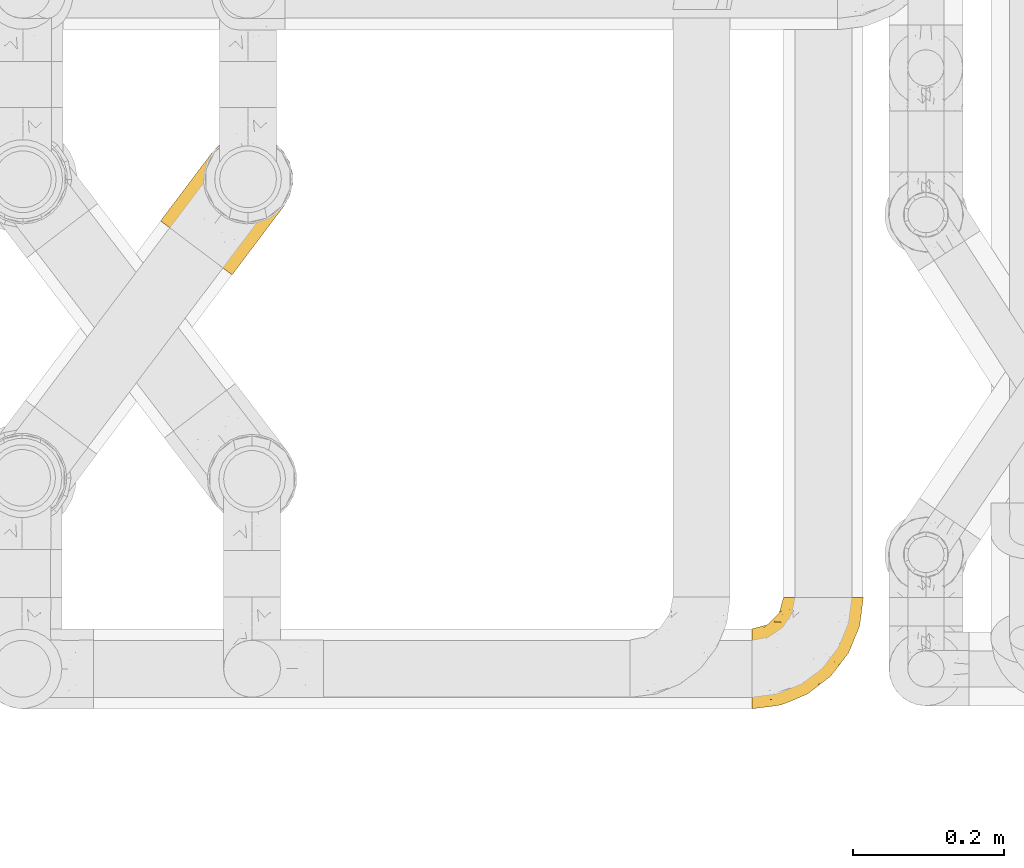
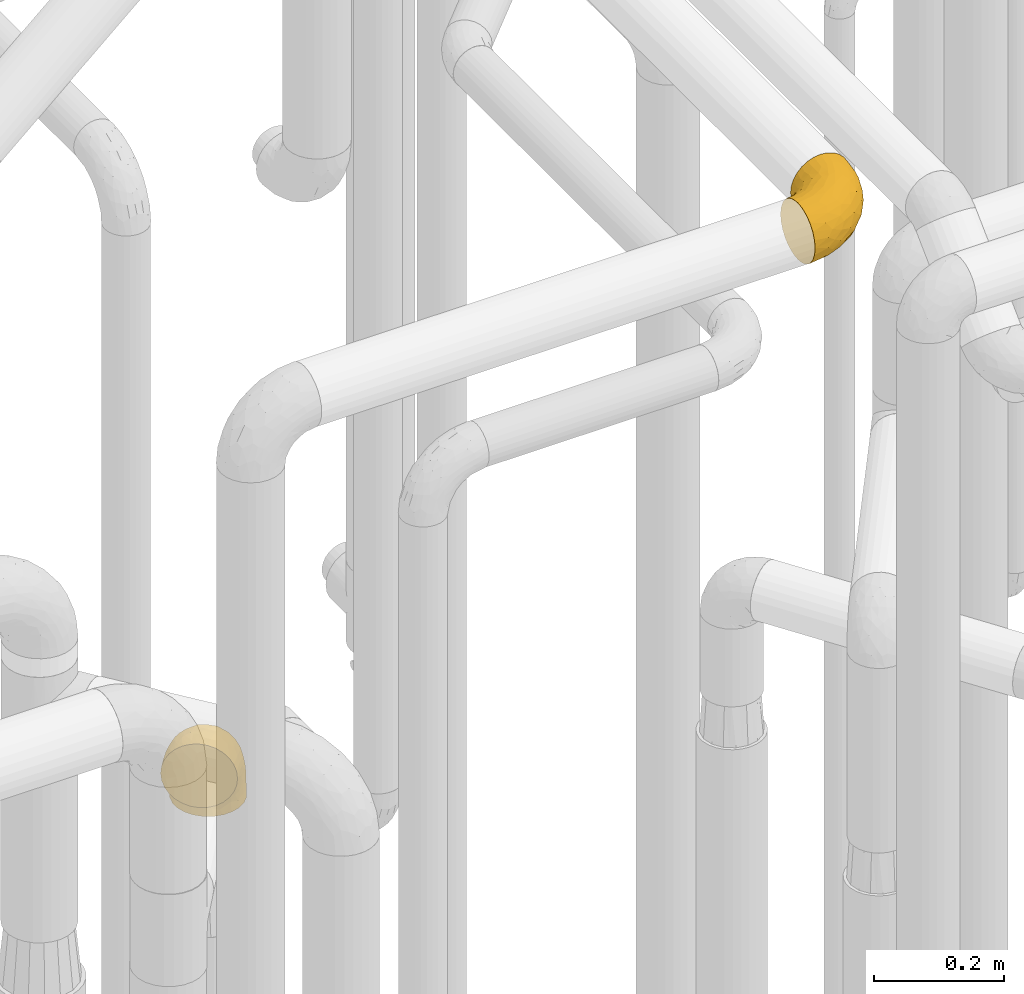
# One storey, part 383 of 827: 2 coverings.
"""IFC2X3 building model written with IfcOpenShell, lengths in millimetres."""

import ifcopenshell
import ifcopenshell.guid

model = None  # the IFC model being written
_history = None  # IfcOwnerHistory: only IFC2X3 demands one
_inside = {}  # id of a spatial element -> (the spatial element, [elements in it])
_under = {}  # id of a project, library or spatial element -> (it, [spatial elements below it])
_declared = {}  # id of a project -> (the project, [libraries it declares])
_typed = {}  # id of a type object -> (the type object, [elements of that type])
_made_of = {}  # id of a material, layer set ... -> (it, [elements and type objects made of it])


def new_model(schema):
    """Start an empty IFC model of exactly this schema.

    Asked for "IFC4X3", IfcOpenShell would pick the latest addendum, in which some entities
    have other attributes; the version numbers below select the first issue.
    IFC2X3 requires an IfcOwnerHistory on every rooted entity: one is made here for all.
    """
    global model, _history
    if schema == "IFC4X3":
        model = ifcopenshell.file(schema_version=(4, 3, 0, 0))
    else:
        model = ifcopenshell.file(schema=schema)
    _inside.clear()
    _under.clear()
    _declared.clear()
    _typed.clear()
    _made_of.clear()
    _history = None
    if model.schema == "IFC2X3":
        org = make("IfcOrganization", Name="unknown")
        user = make(
            "IfcPersonAndOrganization",
            ThePerson=make("IfcPerson", FamilyName="unknown"),
            TheOrganization=org,
        )
        app = make(
            "IfcApplication",
            ApplicationDeveloper=org,
            Version="unknown",
            ApplicationFullName="unknown",
            ApplicationIdentifier="unknown",
        )
        _history = make(
            "IfcOwnerHistory",
            OwningUser=user,
            OwningApplication=app,
            ChangeAction="ADDED",
            CreationDate=0,
        )
    return model


def make(cls, **values):
    """One entity of the class cls with the attributes given. An attribute that is None is left unset."""
    return model.create_entity(
        cls, **{name: value for name, value in values.items() if value is not None}
    )


def entity(cls, *values):
    """Any entity or typed value of the class cls, its attributes in the order of the schema. None: left unset."""
    e = model.create_entity(cls)
    for i, value in enumerate(values):
        if value is not None:
            e[i] = value
    return e


def rooted(cls, **values):
    """An entity with a GlobalId (a new one), such as an element, a storey or a relation."""
    return make(cls, GlobalId=ifcopenshell.guid.new(), OwnerHistory=_history, **values)


def si_unit(unit_type, name, prefix=None):
    """IfcSIUnit, for example si_unit("LENGTHUNIT", "METRE", prefix="MILLI")."""
    return make("IfcSIUnit", UnitType=unit_type, Prefix=prefix, Name=name)


def converted_unit(unit_type, name, factor, base, dimensions=None, offset=None):
    """IfcConversionBasedUnit, such as the inch: factor (a typed value) times the base unit."""
    return make(
        "IfcConversionBasedUnit"
        if offset is None
        else "IfcConversionBasedUnitWithOffset",
        ConversionOffset=offset,
        Dimensions=None
        if dimensions is None
        else entity("IfcDimensionalExponents", *dimensions),
        UnitType=unit_type,
        Name=name,
        ConversionFactor=make(
            "IfcMeasureWithUnit", ValueComponent=factor, UnitComponent=base
        ),
    )


def derived_unit(unit_type, elements):
    """IfcDerivedUnit: a product of units, each with its exponent."""
    return make(
        "IfcDerivedUnit",
        Elements=[
            make("IfcDerivedUnitElement", Unit=unit, Exponent=power)
            for unit, power in elements
        ],
        UnitType=unit_type,
    )


def assignment(units):
    """IfcUnitAssignment: the units of a project."""
    return None if units is None else make("IfcUnitAssignment", Units=units)


def point(xyz):
    """IfcCartesianPoint."""
    return None if xyz is None else make("IfcCartesianPoint", Coordinates=xyz)


def direction(xyz):
    """IfcDirection."""
    return None if xyz is None else make("IfcDirection", DirectionRatios=xyz)


def frame(location, z_axis=None, x_axis=None):
    """IfcAxis2Placement3D, a coordinate frame: its origin and axes. An axis left out is left unset."""
    return make(
        "IfcAxis2Placement3D",
        Location=point(location),
        Axis=direction(z_axis),
        RefDirection=direction(x_axis),
    )


def origin():
    """The frame at (0, 0, 0) with its axes left unset."""
    return frame((0.0, 0.0, 0.0))


def place(relative_to, where):
    """IfcLocalPlacement: puts the frame where relative to a parent placement (None: the world)."""
    return make(
        "IfcLocalPlacement", PlacementRelTo=relative_to, RelativePlacement=where
    )


def context(
    kind, dimensions, precision=None, world=None, true_north=None, identifier=None
):
    """IfcGeometricRepresentationContext, for example the 3D "Model" context."""
    return make(
        "IfcGeometricRepresentationContext",
        ContextIdentifier=identifier,
        ContextType=kind,
        CoordinateSpaceDimension=dimensions,
        Precision=precision,
        WorldCoordinateSystem=world,
        TrueNorth=true_north,
    )


def subcontext(parent, identifier, kind, view, scale=None):
    """IfcGeometricRepresentationSubContext, for example "Body" below "Model"."""
    return make(
        "IfcGeometricRepresentationSubContext",
        ContextIdentifier=identifier,
        ContextType=kind,
        ParentContext=parent,
        TargetScale=scale,
        TargetView=view,
    )


def project(units=None, contexts=None):
    """IfcProject with its units and contexts."""
    return rooted(
        "IfcProject",
        Name="project",
        RepresentationContexts=contexts,
        UnitsInContext=assignment(units),
    )


def spatial(cls, under=None, at=None, **own):
    """A site, building, storey or space (cls), placed at a placement, below another one or the project."""
    s = rooted(cls, ObjectPlacement=at, **own)
    if under is not None:
        _under.setdefault(under.id(), (under, []))[1].append(s)
    return s


def faces_of(points, faces, orient=None, outer=None):
    """IfcFace entities. A face is a list of loops; a loop is a list of indices into points, from 0.

    orient and outer hold one flag for each loop. By default every Orientation is true, the
    first loop of a face is its IfcFaceOuterBound and the others are IfcFaceBound.
    """
    made = []
    for i, loops in enumerate(faces):
        bounds = []
        for j, loop in enumerate(loops):
            is_outer = j == 0 if outer is None else outer[i][j]
            bounds.append(
                make(
                    "IfcFaceOuterBound" if is_outer else "IfcFaceBound",
                    Bound=make("IfcPolyLoop", Polygon=[points[k] for k in loop]),
                    Orientation=True if orient is None else orient[i][j],
                )
            )
        made.append(make("IfcFace", Bounds=bounds))
    return made


def faceted_brep(points, faces, orient=None, outer=None, voids=None):
    """IfcFacetedBrep: a solid bounded by flat faces; with voids (closed shells), ...WithVoids."""
    shared = [point(p) for p in points]
    hull = make("IfcClosedShell", CfsFaces=faces_of(shared, faces, orient, outer))
    if voids is None:
        return make("IfcFacetedBrep", Outer=hull)
    return make(
        "IfcFacetedBrepWithVoids",
        Outer=hull,
        Voids=[
            make(cls, CfsFaces=faces_of(shared, fs, o, b)) for cls, fs, o, b in voids
        ],
    )


def shape(context_of_items, identifier, shape_type, items):
    """IfcShapeRepresentation: the items that make up one representation, for example the "Body"."""
    return make(
        "IfcShapeRepresentation",
        ContextOfItems=context_of_items,
        RepresentationIdentifier=identifier,
        RepresentationType=shape_type,
        Items=items,
    )


def made_of(thing, what):
    """Note that an element or type object is made of a material, layer set ...; save() writes the relation."""
    if what is not None:
        _made_of.setdefault(what.id(), (what, []))[1].append(thing)
    return thing


def element(
    cls,
    number,
    at=None,
    inside=None,
    cuts=None,
    type_object=None,
    material=None,
    context=None,
    identifier="Body",
    shape_type=None,
    held_by="IfcProductDefinitionShape",
    body=None,
    shapes=None,
    **own,
):
    """One element of the class cls, such as IfcWall. Its Tag is "e" and its number.

    at: its placement. inside: the storey or other place that contains it. cuts: it is an
    opening in that element (IfcRelVoidsElement). A single representation is given by context,
    identifier, shape_type and body (its items); several are given by shapes. held_by: the class
    of the entity that holds the representations. save() writes the other relations.
    """
    e = rooted(cls, Tag="e%d" % number, ObjectPlacement=at, **own)
    if body is not None:
        shapes = [shape(context, identifier, shape_type, body)]
    if shapes is not None:
        e.Representation = make(held_by, Representations=shapes)
    if inside is not None:
        _inside.setdefault(inside.id(), (inside, []))[1].append(e)
    if cuts is not None:
        rooted(
            "IfcRelVoidsElement", RelatingBuildingElement=cuts, RelatedOpeningElement=e
        )
    if type_object is not None:
        _typed.setdefault(type_object.id(), (type_object, []))[1].append(e)
    return made_of(e, material)


def aggregate(whole, parts):
    """IfcRelAggregates: a whole, such as a stair, and the parts it consists of."""
    return rooted("IfcRelAggregates", RelatingObject=whole, RelatedObjects=parts)


def save(model, path):
    """Write the relations noted so far, then the file.

    IfcRelAggregates (storeys below a building ...), IfcRelContainedInSpatialStructure (elements
    in a storey), IfcRelDefinesByType, IfcRelAssociatesMaterial and IfcRelDeclares: one each for
    every whole, place, type object, material and project.
    """
    for whole, parts in _under.values():
        aggregate(whole, parts)
    for where, things in _inside.values():
        rooted(
            "IfcRelContainedInSpatialStructure",
            RelatedElements=things,
            RelatingStructure=where,
        )
    for kind, things in _typed.values():
        rooted("IfcRelDefinesByType", RelatedObjects=things, RelatingType=kind)
    for what, things in _made_of.values():
        rooted("IfcRelAssociatesMaterial", RelatedObjects=things, RelatingMaterial=what)
    for by, libraries in _declared.values():
        rooted("IfcRelDeclares", RelatingContext=by, RelatedDefinitions=libraries)
    model.write(path)


model = new_model("IFC2X3")

# Units and contexts
model_context = context("Model", 3, precision=0.01, world=origin(), true_north=direction((6.12303176911189e-17, 1.0)))
body_context = subcontext(model_context, "Body", "Model", "MODEL_VIEW")
ifc_project = project(units=[si_unit("LENGTHUNIT", "METRE", prefix="MILLI"), si_unit("AREAUNIT", "SQUARE_METRE"), si_unit("VOLUMEUNIT", "CUBIC_METRE"), converted_unit("PLANEANGLEUNIT", "DEGREE", entity("IfcRatioMeasure", 0.0174532925199433), si_unit("PLANEANGLEUNIT", "RADIAN"), dimensions=[0, 0, 0, 0, 0, 0, 0]), si_unit("MASSUNIT", "GRAM", prefix="KILO"), derived_unit("MASSDENSITYUNIT", [(si_unit("MASSUNIT", "GRAM", prefix="KILO"), 1), (si_unit("LENGTHUNIT", "METRE"), -3)]), derived_unit("MOMENTOFINERTIAUNIT", [(si_unit("LENGTHUNIT", "METRE"), 4)]), si_unit("TIMEUNIT", "SECOND"), si_unit("FREQUENCYUNIT", "HERTZ"), si_unit("THERMODYNAMICTEMPERATUREUNIT", "DEGREE_CELSIUS"), derived_unit("THERMALTRANSMITTANCEUNIT", [(si_unit("MASSUNIT", "GRAM", prefix="KILO"), 1), (si_unit("THERMODYNAMICTEMPERATUREUNIT", "KELVIN"), -1), (si_unit("TIMEUNIT", "SECOND"), -3)]), derived_unit("VOLUMETRICFLOWRATEUNIT", [(si_unit("LENGTHUNIT", "METRE"), 3), (si_unit("TIMEUNIT", "SECOND"), -1)]), derived_unit("MASSFLOWRATEUNIT", [(si_unit("MASSUNIT", "GRAM", prefix="KILO"), 1), (si_unit("TIMEUNIT", "SECOND"), -1)]), derived_unit("ROTATIONALFREQUENCYUNIT", [(si_unit("TIMEUNIT", "SECOND"), -1)]), si_unit("ELECTRICCURRENTUNIT", "AMPERE"), si_unit("ELECTRICVOLTAGEUNIT", "VOLT"), si_unit("POWERUNIT", "WATT"), si_unit("FORCEUNIT", "NEWTON", prefix="KILO"), si_unit("ILLUMINANCEUNIT", "LUX"), si_unit("LUMINOUSFLUXUNIT", "LUMEN"), si_unit("LUMINOUSINTENSITYUNIT", "CANDELA"), derived_unit("USERDEFINED", [(si_unit("MASSUNIT", "GRAM", prefix="KILO"), -1), (si_unit("LENGTHUNIT", "METRE"), -2), (si_unit("TIMEUNIT", "SECOND"), 3), (si_unit("LUMINOUSFLUXUNIT", "LUMEN"), 1)]), derived_unit("LINEARVELOCITYUNIT", [(si_unit("LENGTHUNIT", "METRE"), 1), (si_unit("TIMEUNIT", "SECOND"), -1)]), si_unit("PRESSUREUNIT", "PASCAL"), derived_unit("USERDEFINED", [(si_unit("LENGTHUNIT", "METRE"), -2), (si_unit("MASSUNIT", "GRAM", prefix="KILO"), 1), (si_unit("TIMEUNIT", "SECOND"), -2)]), derived_unit("LINEARFORCEUNIT", [(si_unit("MASSUNIT", "GRAM", prefix="KILO"), 1), (si_unit("LENGTHUNIT", "METRE"), 1), (si_unit("TIMEUNIT", "SECOND"), -2), (si_unit("LENGTHUNIT", "METRE"), -1)]), derived_unit("PLANARFORCEUNIT", [(si_unit("MASSUNIT", "GRAM", prefix="KILO"), 1), (si_unit("LENGTHUNIT", "METRE"), 1), (si_unit("TIMEUNIT", "SECOND"), -2), (si_unit("LENGTHUNIT", "METRE"), -2)])], contexts=[model_context])

# Site, building, storey
site_placement = place(None, origin())
site = spatial("IfcSite", under=ifc_project, at=site_placement, CompositionType="ELEMENT")
building_placement = place(site_placement, origin())
building = spatial("IfcBuilding", under=site, at=building_placement, CompositionType="ELEMENT")
storey_placement = place(building_placement, frame((0.0, 0.0, 28200.0)))
storey = spatial("IfcBuildingStorey", under=building, at=storey_placement, Name="08", CompositionType="ELEMENT", Elevation=28200.0)

# Coverings
covering_1_placement = place(storey_placement, frame((46460.18, 13582.19, 3145.4)))
element("IfcCovering", 1, at=covering_1_placement, inside=storey, Name=":ADSK_", ObjectType=":ADSK_", PredefinedType="INSULATION", context=body_context, shape_type="Brep", body=[
    faceted_brep([(148.32, 149.65, 66.44), (149.65, 149.65, 54.65), (148.31, 149.65, 42.84), (144.39, 149.65, 31.62), (138.06, 149.65, 21.56), (129.66, 149.65, 13.16), (119.6, 149.65, 6.84), (108.39, 149.65, 2.92), (96.6, 149.65, 1.6), (84.79, 149.65, 2.93), (73.57, 149.65, 6.85), (63.51, 149.65, 13.18), (55.11, 149.65, 21.58), (48.79, 149.65, 31.64), (44.87, 149.65, 42.85), (43.55, 149.65, 54.65), (44.88, 149.65, 66.46), (48.8, 149.65, 77.67), (55.13, 149.65, 87.73), (63.53, 149.65, 96.13), (73.59, 149.65, 102.45), (84.8, 149.65, 106.37), (96.6, 149.65, 107.7), (108.41, 149.65, 106.36), (119.62, 149.65, 102.44), (129.68, 149.65, 96.11), (138.08, 149.65, 87.71), (144.4, 149.65, 77.65), (1.6, 105.89, 40.91), (1.6, 100.59, 28.12), (1.6, 92.16, 17.13), (1.6, 81.17, 8.7), (1.6, 68.38, 3.4), (1.6, 54.65, 1.6), (1.6, 40.91, 3.4), (1.6, 28.12, 8.7), (1.6, 17.13, 17.13), (1.6, 8.7, 28.12), (1.6, 3.4, 40.91), (1.6, 1.6, 54.65), (1.6, 3.4, 68.38), (1.6, 8.7, 81.17), (1.6, 17.13, 92.16), (1.6, 28.12, 100.59), (1.6, 40.91, 105.89), (1.6, 54.65, 107.7), (1.6, 68.38, 105.89), (1.6, 81.17, 100.59), (1.6, 92.16, 92.16), (1.6, 100.59, 81.17), (1.6, 105.89, 68.38), (1.6, 107.7, 54.65), (27.97, 14.05, 85.53), (37.09, 9.45, 73.42), (58.27, 22.36, 83.77), (27.13, 4.7, 64.22), (39.91, 6.64, 54.65), (109.11, 81.47, 96.72), (94.41, 56.83, 93.36), (110.94, 64.02, 84.47), (89.69, 34.04, 71.37), (75.62, 21.43, 54.65), (106.28, 44.96, 54.65), (60.12, 49.8, 103.47), (41.41, 35.43, 100.91), (63.22, 42.1, 99.1), (32.05, 43.59, 105.43), (52.13, 57.88, 106.79), (123.27, 91.8, 89.81), (129.32, 88.01, 79.59), (138.3, 115.65, 81.29), (62.95, 18.94, 74.01), (55.89, 12.83, 64.14), (37.4, 24.96, 94.75), (144.6, 111.33, 54.65), (142.66, 113.8, 70.74), (117.85, 60.89, 68.3), (134.01, 86.24, 66.05), (89.25, 65.84, 100.73), (103.34, 124.58, 106.78), (113.52, 121.36, 103.6), (57.43, 72.79, 107.7), (44.19, 66.04, 107.7), (30.95, 59.29, 107.7), (77.98, 73.26, 106.07), (132.66, 121.69, 90.59), (121.52, 109.82, 97.43), (86.93, 40.11, 84.51), (68.4, 36.57, 93.3), (78.45, 93.81, 107.7), (67.94, 83.3, 107.7), (94.53, 136.6, 107.7), (91.95, 120.29, 107.7), (93.36, 99.11, 106.79), (85.2, 107.05, 107.7), (101.45, 91.12, 103.47), (129.81, 75.62, 54.65), (16.27, 56.97, 107.7), (42.46, 126.65, 76.99), (40.4, 116.55, 84.28), (49.71, 120.09, 91.11), (39.4, 76.06, 106.26), (31.26, 83.69, 102.6), (27.7, 71.88, 106.08), (16.7, 66.92, 106.56), (70.67, 110.43, 105.36), (81.69, 121.31, 106.74), (16.68, 81.0, 101.59), (22.57, 113.32, 54.65), (14.26, 111.09, 54.65), (17.68, 109.14, 67.71), (19.58, 95.86, 91.36), (33.49, 99.07, 94.33), (33.01, 106.92, 87.1), (40.69, 131.39, 65.84), (40.15, 136.98, 54.65), (37.93, 128.67, 54.65), (31.04, 117.07, 68.92), (45.29, 96.39, 100.82), (23.55, 106.61, 79.83), (11.36, 103.72, 77.13), (59.1, 92.14, 105.9), (57.42, 107.13, 101.53), (68.96, 98.03, 106.72), (20.38, 88.38, 97.75), (72.46, 130.66, 103.08), (83.66, 135.45, 106.39), (60.66, 123.57, 98.1), (61.01, 137.75, 95.02), (51.85, 133.2, 86.9), (46.07, 138.8, 74.42), (30.25, 120.99, 54.65), (46.65, 84.53, 105.28), (43.0, 108.72, 92.87), (19.58, 95.86, 17.93), (72.44, 130.67, 6.22), (17.67, 109.13, 41.58), (78.45, 93.81, 1.6), (68.97, 98.02, 2.57), (70.65, 110.43, 3.94), (40.69, 131.4, 43.46), (42.45, 126.66, 32.32), (31.04, 117.08, 40.38), (42.99, 108.74, 16.44), (45.18, 96.31, 8.47), (33.46, 99.11, 15.01), (60.64, 123.58, 11.21), (57.37, 107.12, 7.78), (57.43, 72.79, 1.6), (44.19, 66.04, 1.6), (39.35, 76.07, 3.04), (16.27, 56.97, 1.6), (16.7, 66.92, 2.73), (91.95, 120.29, 1.6), (85.2, 107.05, 1.6), (81.68, 121.26, 2.55), (46.68, 84.46, 3.98), (31.26, 83.69, 6.69), (16.68, 81.0, 7.7), (27.7, 71.88, 3.21), (60.99, 137.76, 14.28), (51.84, 133.21, 22.42), (40.41, 116.58, 25.02), (49.72, 120.1, 18.18), (46.06, 138.81, 34.89), (94.53, 136.6, 1.6), (11.35, 103.72, 32.17), (33.02, 106.96, 22.23), (83.65, 135.44, 2.91), (20.38, 88.38, 11.54), (67.94, 83.3, 1.6), (23.53, 106.6, 29.46), (59.12, 92.12, 3.38), (30.95, 59.29, 1.6), (58.27, 22.36, 25.52), (27.97, 14.05, 23.76), (37.4, 24.96, 14.54), (41.41, 35.43, 8.38), (27.21, 4.71, 45.07), (37.09, 9.45, 35.87), (53.2, 11.79, 45.14), (52.13, 57.88, 2.5), (103.34, 124.57, 2.51), (113.5, 121.37, 5.68), (101.45, 91.12, 5.82), (94.41, 56.83, 15.93), (109.08, 81.48, 12.54), (110.95, 64.05, 24.81), (93.36, 99.11, 2.5), (77.98, 73.26, 3.22), (32.05, 43.59, 3.86), (64.63, 19.5, 35.85), (123.25, 91.8, 19.47), (132.65, 121.7, 18.68), (129.32, 88.04, 29.68), (139.96, 123.34, 27.95), (117.85, 60.89, 40.99), (89.69, 34.04, 37.92), (121.51, 109.85, 11.85), (63.23, 42.1, 10.19), (89.17, 65.78, 8.55), (142.66, 113.81, 38.53), (68.4, 36.57, 15.99), (86.94, 40.12, 24.79), (60.12, 49.8, 5.82), (133.2, 86.08, 40.56)], [[[0, 1, 2, 3, 4, 5, 6, 7, 8, 9, 10, 11, 12, 13, 14, 15, 16, 17, 18, 19, 20, 21, 22, 23, 24, 25, 26, 27]], [[28, 29, 30, 31, 32, 33, 34, 35, 36, 37, 38, 39, 40, 41, 42, 43, 44, 45, 46, 47, 48, 49, 50, 51]], [[52, 53, 54]], [[55, 39, 56]], [[57, 58, 59]], [[60, 61, 62]], [[63, 64, 65]], [[66, 63, 67]], [[68, 69, 70]], [[53, 71, 54]], [[41, 40, 53]], [[53, 72, 71]], [[73, 42, 52]], [[42, 41, 52]], [[74, 0, 75]], [[69, 76, 77]], [[43, 73, 64]], [[45, 44, 66]], [[57, 78, 58]], [[23, 79, 80]], [[67, 81, 82, 83]], [[67, 84, 81]], [[24, 23, 80]], [[25, 85, 26]], [[86, 85, 25]], [[42, 73, 43]], [[0, 27, 75]], [[25, 24, 86]], [[70, 26, 85]], [[0, 74, 1]], [[68, 85, 86]], [[66, 64, 63]], [[60, 59, 87]], [[54, 87, 88]], [[76, 60, 62]], [[84, 89, 90, 81]], [[79, 22, 91, 92]], [[77, 74, 75]], [[93, 92, 94, 89]], [[80, 86, 24]], [[40, 55, 53]], [[76, 59, 60]], [[93, 84, 95]], [[76, 62, 96]], [[55, 72, 53]], [[70, 27, 26]], [[75, 70, 69]], [[78, 84, 63]], [[93, 79, 92]], [[95, 86, 80]], [[77, 76, 96]], [[59, 69, 68]], [[57, 68, 86]], [[68, 57, 59]], [[59, 58, 87]], [[76, 69, 59]], [[88, 87, 58]], [[87, 54, 71]], [[86, 95, 57]], [[78, 57, 95]], [[84, 78, 95]], [[78, 63, 65]], [[58, 78, 65]], [[54, 88, 73]], [[84, 93, 89]], [[79, 95, 80]], [[79, 93, 95]], [[22, 79, 23]], [[66, 83, 97, 45]], [[84, 67, 63]], [[83, 66, 67]], [[64, 44, 43]], [[64, 66, 44]], [[65, 73, 88]], [[53, 52, 41]], [[73, 52, 54]], [[73, 65, 64]], [[65, 88, 58]], [[39, 55, 40]], [[72, 55, 56]], [[56, 61, 72]], [[60, 72, 61]], [[72, 60, 71]], [[87, 71, 60]], [[27, 70, 75]], [[68, 70, 85]], [[74, 77, 96]], [[69, 77, 75]], [[98, 99, 100]], [[46, 45, 97]], [[101, 102, 103]], [[103, 104, 83]], [[105, 94, 106]], [[107, 103, 102]], [[108, 109, 51, 110]], [[111, 112, 113]], [[114, 115, 116]], [[47, 104, 107]], [[110, 117, 108]], [[49, 48, 111]], [[102, 118, 112]], [[119, 120, 111]], [[50, 49, 120]], [[121, 122, 118]], [[105, 123, 89]], [[124, 48, 107]], [[20, 19, 125]], [[121, 81, 90]], [[117, 119, 99]], [[21, 20, 126]], [[22, 21, 91]], [[105, 125, 127]], [[110, 51, 50]], [[19, 128, 125]], [[16, 15, 115]], [[129, 98, 100]], [[126, 91, 21]], [[128, 129, 127]], [[122, 123, 105]], [[114, 117, 98]], [[17, 16, 130]], [[18, 128, 19]], [[129, 18, 17]], [[125, 106, 126]], [[115, 114, 16]], [[130, 129, 17]], [[114, 98, 130]], [[117, 116, 131, 108]], [[99, 119, 113]], [[122, 121, 123]], [[92, 126, 106]], [[105, 127, 122]], [[132, 121, 118]], [[114, 130, 16]], [[129, 130, 98]], [[50, 120, 110]], [[129, 128, 18]], [[125, 128, 127]], [[125, 126, 20]], [[91, 126, 92]], [[105, 89, 94]], [[105, 106, 125]], [[94, 92, 106]], [[100, 122, 127]], [[118, 122, 133]], [[112, 118, 133]], [[132, 118, 102]], [[132, 102, 101]], [[81, 121, 132]], [[82, 103, 83]], [[132, 101, 81]], [[104, 47, 46]], [[124, 107, 102]], [[48, 47, 107]], [[113, 112, 133]], [[112, 111, 124]], [[99, 113, 133]], [[111, 113, 119]], [[99, 133, 100]], [[117, 99, 98]], [[122, 100, 133]], [[127, 129, 100]], [[103, 82, 101]], [[81, 101, 82]], [[112, 124, 102]], [[48, 124, 111]], [[104, 103, 107]], [[46, 97, 104]], [[111, 120, 49]], [[83, 104, 97]], [[110, 120, 119]], [[117, 110, 119]], [[116, 117, 114]], [[89, 123, 90]], [[90, 123, 121]], [[30, 29, 134]], [[11, 10, 135]], [[51, 109, 108, 136]], [[137, 138, 139]], [[140, 141, 142]], [[143, 144, 145]], [[146, 139, 147]], [[148, 149, 150]], [[151, 32, 152]], [[153, 154, 155]], [[156, 150, 157]], [[158, 157, 159]], [[108, 142, 136]], [[31, 158, 152]], [[160, 161, 12]], [[162, 163, 143]], [[140, 142, 116]], [[142, 141, 162]], [[14, 164, 140]], [[14, 140, 115]], [[9, 8, 165]], [[160, 12, 11]], [[141, 164, 161]], [[13, 12, 161]], [[14, 115, 15]], [[28, 166, 29]], [[135, 139, 146]], [[141, 163, 162]], [[135, 146, 160]], [[143, 167, 162]], [[29, 166, 134]], [[116, 142, 108, 131]], [[165, 153, 168]], [[10, 9, 168]], [[168, 135, 10]], [[138, 147, 139]], [[158, 169, 157]], [[14, 13, 164]], [[116, 115, 140]], [[145, 167, 143]], [[135, 160, 11]], [[168, 153, 155]], [[138, 137, 170]], [[157, 144, 156]], [[147, 144, 143]], [[161, 164, 13]], [[140, 164, 141]], [[142, 171, 136]], [[136, 171, 166]], [[161, 160, 146]], [[165, 168, 9]], [[155, 139, 135]], [[139, 154, 137]], [[168, 155, 135]], [[139, 155, 154]], [[144, 147, 172]], [[163, 147, 143]], [[156, 144, 172]], [[157, 169, 145]], [[172, 148, 156]], [[173, 159, 149]], [[159, 157, 150]], [[152, 159, 173]], [[159, 152, 158]], [[31, 30, 158]], [[169, 30, 134]], [[157, 145, 144]], [[167, 134, 171]], [[134, 167, 145]], [[171, 142, 162]], [[162, 167, 171]], [[163, 141, 161]], [[161, 146, 163]], [[147, 163, 146]], [[148, 150, 156]], [[149, 159, 150]], [[30, 169, 158]], [[145, 169, 134]], [[151, 33, 32]], [[31, 152, 32]], [[152, 173, 151]], [[28, 51, 136]], [[134, 166, 171]], [[28, 136, 166]], [[138, 170, 172]], [[147, 138, 172]], [[148, 172, 170]], [[174, 175, 176]], [[35, 34, 177]], [[178, 179, 180]], [[181, 173, 149, 148]], [[182, 183, 184]], [[185, 186, 187]], [[188, 189, 137]], [[190, 33, 151, 173]], [[191, 179, 174]], [[34, 190, 177]], [[39, 38, 178]], [[192, 193, 194]], [[4, 3, 195]], [[175, 179, 37]], [[38, 37, 179]], [[35, 176, 36]], [[196, 62, 197]], [[181, 190, 173]], [[37, 36, 175]], [[183, 6, 198]], [[189, 148, 170, 137]], [[185, 199, 200]], [[3, 2, 201]], [[202, 185, 203]], [[8, 7, 182]], [[200, 184, 186]], [[183, 7, 6]], [[181, 189, 204]], [[200, 189, 184]], [[5, 198, 6]], [[187, 203, 185]], [[195, 3, 201]], [[205, 196, 194]], [[62, 61, 197]], [[186, 198, 192]], [[180, 179, 191]], [[2, 1, 74]], [[198, 193, 192]], [[193, 5, 4]], [[194, 193, 195]], [[2, 74, 201]], [[5, 193, 198]], [[205, 74, 96]], [[188, 137, 154, 153]], [[62, 196, 96]], [[56, 178, 180]], [[198, 184, 183]], [[184, 188, 182]], [[203, 197, 191]], [[205, 194, 201]], [[187, 192, 194]], [[192, 187, 186]], [[194, 196, 187]], [[197, 187, 196]], [[197, 203, 187]], [[202, 174, 176]], [[200, 186, 185]], [[184, 198, 186]], [[199, 185, 202]], [[189, 200, 204]], [[174, 202, 203]], [[176, 177, 199]], [[189, 181, 148]], [[190, 181, 204]], [[190, 204, 177]], [[190, 34, 33]], [[188, 153, 182]], [[189, 188, 184]], [[182, 153, 165, 8]], [[183, 182, 7]], [[199, 177, 204]], [[35, 177, 176]], [[176, 175, 36]], [[179, 175, 174]], [[200, 199, 204]], [[176, 199, 202]], [[203, 191, 174]], [[180, 197, 61]], [[197, 180, 191]], [[61, 56, 180]], [[39, 178, 56]], [[38, 179, 178]], [[194, 195, 201]], [[4, 195, 193]], [[74, 205, 201]], [[96, 196, 205]]]),
])
covering_2_placement = place(storey_placement, frame((45675.39, 14158.2, 1984.4)))
element("IfcCovering", 2, at=covering_2_placement, inside=storey, Name=":ADSK_", ObjectType=":ADSK_", PredefinedType="INSULATION", context=body_context, shape_type="Brep", body=[
    faceted_brep([(96.55, 1.6, 115.6), (95.36, 2.49, 128.83), (91.85, 5.14, 141.39), (86.19, 9.4, 152.67), (78.67, 15.07, 162.08), (69.67, 21.86, 169.16), (59.63, 29.42, 173.56), (49.07, 37.37, 175.05), (38.51, 45.34, 173.55), (28.47, 52.9, 169.16), (19.47, 59.68, 162.07), (11.95, 65.35, 152.66), (6.29, 69.61, 141.38), (2.78, 72.26, 128.81), (1.6, 73.15, 115.6), (2.79, 72.25, 102.36), (6.3, 69.61, 89.8), (11.96, 65.34, 78.52), (19.48, 59.68, 69.11), (28.48, 52.89, 62.03), (38.52, 45.33, 57.63), (49.07, 37.37, 56.15), (59.64, 29.41, 57.64), (69.68, 21.85, 62.03), (78.68, 15.06, 69.12), (86.2, 9.4, 78.54), (91.85, 5.14, 89.81), (95.36, 2.49, 102.38), (70.83, 91.82, 1.6), (62.96, 105.19, 1.6), (58.81, 120.14, 1.6), (58.67, 135.66, 1.6), (62.56, 150.69, 1.6), (70.2, 164.2, 1.6), (81.08, 175.26, 1.6), (94.45, 183.14, 1.6), (109.41, 187.29, 1.6), (124.93, 187.42, 1.6), (139.95, 183.54, 1.6), (153.46, 175.9, 1.6), (164.53, 165.02, 1.6), (172.41, 151.65, 1.6), (176.55, 136.69, 1.6), (176.69, 121.17, 1.6), (172.8, 106.15, 1.6), (165.16, 92.64, 1.6), (154.28, 81.57, 1.6), (140.91, 73.69, 1.6), (125.95, 69.55, 1.6), (110.44, 69.41, 1.6), (95.41, 73.3, 1.6), (81.9, 80.94, 1.6), (172.67, 143.74, 32.35), (164.87, 155.93, 43.24), (165.31, 137.06, 67.79), (158.98, 165.35, 39.06), (149.9, 171.18, 46.49), (115.26, 45.28, 143.21), (135.25, 72.63, 128.0), (121.7, 67.86, 144.51), (145.71, 134.22, 104.87), (139.47, 157.34, 88.32), (122.89, 135.32, 124.24), (164.18, 99.3, 70.72), (171.84, 114.1, 48.42), (165.43, 109.28, 74.22), (170.47, 103.96, 37.66), (161.69, 89.73, 61.68), (114.83, 77.84, 151.61), (96.67, 50.75, 162.2), (158.81, 146.51, 73.52), (153.68, 158.42, 66.93), (173.47, 127.59, 43.54), (76.09, 73.23, 169.14), (88.8, 59.97, 166.98), (123.9, 111.28, 137.86), (103.92, 88.97, 156.83), (151.12, 86.48, 103.08), (149.48, 98.76, 111.05), (113.81, 26.22, 122.98), (131.9, 50.2, 111.19), (134.32, 59.68, 120.32), (152.06, 75.25, 68.6), (156.93, 81.72, 52.71), (161.8, 88.18, 36.82), (101.27, 106.63, 151.81), (112.81, 30.69, 134.29), (100.99, 39.17, 155.8), (152.98, 120.26, 102.22), (136.04, 97.06, 130.43), (163.81, 118.15, 80.3), (149.86, 75.43, 92.65), (136.88, 55.11, 93.82), (144.47, 65.18, 81.21), (105.35, 13.27, 113.28), (117.75, 29.73, 110.02), (127.32, 42.42, 101.92), (163.77, 90.79, 16.21), (123.14, 41.56, 84.67), (105.81, 23.04, 87.66), (106.64, 33.78, 74.04), (152.47, 79.51, 21.09), (148.94, 75.48, 35.03), (127.67, 58.34, 52.93), (119.86, 60.91, 39.76), (129.66, 65.35, 34.91), (122.22, 48.52, 67.69), (82.87, 57.96, 44.31), (98.96, 55.49, 44.87), (85.77, 45.42, 54.18), (61.64, 54.04, 51.99), (72.11, 46.64, 53.35), (137.61, 71.42, 18.29), (121.94, 66.54, 23.44), (104.28, 64.61, 28.92), (104.38, 69.31, 13.79), (92.1, 72.08, 18.1), (84.56, 68.06, 32.62), (79.4, 77.62, 22.47), (105.96, 16.64, 100.59), (134.72, 54.71, 78.3), (138.77, 62.32, 62.67), (74.64, 34.93, 58.76), (89.62, 31.93, 64.93), (99.68, 46.03, 56.12), (93.76, 21.95, 75.28), (116.64, 30.3, 97.34), (109.23, 43.23, 64.0), (72.29, 68.18, 40.17), (139.69, 68.93, 38.41), (148.51, 72.79, 51.71), (112.93, 52.49, 52.67), (52.2, 111.89, 39.74), (46.01, 102.9, 52.66), (47.57, 118.71, 52.9), (58.06, 141.08, 27.75), (55.71, 142.72, 51.71), (60.03, 148.83, 38.57), (59.54, 75.51, 44.33), (39.63, 110.75, 67.68), (41.92, 126.67, 93.82), (49.51, 136.74, 81.21), (42.14, 124.48, 78.3), (70.58, 88.3, 18.1), (19.66, 87.96, 87.65), (64.53, 99.34, 13.78), (21.94, 76.07, 75.27), (32.67, 74.83, 64.92), (61.08, 148.38, 21.09), (68.81, 162.35, 16.21), (48.33, 130.47, 62.67), (57.03, 115.46, 23.43), (68.78, 79.96, 32.63), (57.39, 131.86, 18.29), (38.12, 96.81, 63.99), (43.43, 88.38, 56.13), (51.63, 62.05, 53.35), (22.8, 101.29, 110.02), (32.36, 113.98, 101.92), (23.66, 100.38, 97.32), (10.39, 84.83, 113.28), (46.69, 74.83, 54.19), (39.69, 61.25, 58.76), (52.74, 90.31, 44.88), (60.05, 97.95, 28.91), (61.97, 153.27, 52.71), (32.69, 109.72, 84.65), (29.76, 91.7, 74.03), (13.47, 86.35, 100.57), (53.75, 122.54, 34.93), (57.1, 146.81, 68.6), (66.84, 159.74, 36.82), (54.43, 133.17, 38.41), (112.86, 176.58, 67.79), (117.25, 185.5, 32.35), (101.5, 181.82, 43.54), (88.99, 176.54, 48.42), (141.8, 178.3, 39.06), (131.12, 181.37, 43.24), (136.6, 171.29, 66.93), (68.37, 160.06, 61.68), (47.02, 125.47, 120.32), (20.51, 96.54, 122.97), (25.07, 96.8, 134.28), (80.41, 150.81, 111.05), (59.18, 129.89, 128.03), (82.46, 137.41, 130.43), (38.58, 120.52, 111.19), (57.88, 144.75, 92.65), (79.62, 172.42, 37.66), (123.74, 172.94, 73.52), (58.35, 115.6, 144.5), (36.48, 87.77, 155.79), (69.83, 111.73, 151.61), (43.74, 80.12, 164.01), (99.5, 129.67, 137.86), (115.53, 156.96, 104.87), (38.42, 103.16, 143.2), (86.12, 169.04, 74.22), (68.14, 148.97, 103.12), (59.84, 81.79, 166.97), (95.11, 169.94, 80.3), (100.11, 160.09, 102.23), (81.09, 106.52, 155.79), (76.87, 165.09, 70.72)], [[[0, 1, 2, 3, 4, 5, 6, 7, 8, 9, 10, 11, 12, 13, 14, 15, 16, 17, 18, 19, 20, 21, 22, 23, 24, 25, 26, 27]], [[28, 29, 30, 31, 32, 33, 34, 35, 36, 37, 38, 39, 40, 41, 42, 43, 44, 45, 46, 47, 48, 49, 50, 51]], [[52, 53, 54]], [[55, 39, 56]], [[57, 58, 59]], [[60, 61, 62]], [[63, 64, 65]], [[66, 63, 67]], [[59, 68, 69]], [[53, 70, 54]], [[41, 40, 53]], [[53, 71, 70]], [[72, 42, 52]], [[42, 41, 52]], [[73, 6, 74]], [[68, 75, 76]], [[43, 72, 64]], [[45, 44, 66]], [[58, 77, 78]], [[79, 80, 81]], [[67, 82, 83, 84]], [[75, 62, 85]], [[2, 1, 86]], [[3, 87, 4]], [[57, 87, 3]], [[42, 72, 43]], [[6, 5, 74]], [[3, 2, 57]], [[69, 4, 87]], [[6, 73, 7]], [[59, 87, 57]], [[66, 64, 63]], [[88, 89, 78]], [[54, 88, 90]], [[75, 60, 62]], [[91, 92, 93, 82]], [[79, 0, 94, 95]], [[76, 73, 74]], [[80, 95, 96, 92]], [[57, 2, 86]], [[56, 71, 55]], [[77, 91, 63]], [[80, 91, 81]], [[67, 91, 82]], [[71, 56, 61]], [[69, 5, 4]], [[74, 69, 68]], [[75, 89, 60]], [[80, 79, 95]], [[81, 57, 86]], [[76, 75, 85]], [[89, 68, 59]], [[58, 57, 81]], [[59, 58, 89]], [[90, 88, 78]], [[75, 68, 89]], [[70, 88, 54]], [[60, 89, 88]], [[77, 58, 81]], [[89, 58, 78]], [[91, 77, 81]], [[77, 63, 65]], [[78, 77, 65]], [[54, 90, 72]], [[91, 80, 92]], [[79, 81, 86]], [[86, 1, 79]], [[0, 79, 1]], [[66, 84, 97, 45]], [[91, 67, 63]], [[84, 66, 67]], [[64, 44, 43]], [[64, 66, 44]], [[65, 72, 90]], [[53, 52, 41]], [[72, 52, 54]], [[72, 65, 64]], [[65, 90, 78]], [[60, 71, 61]], [[55, 71, 53]], [[71, 60, 70]], [[88, 70, 60]], [[53, 40, 55]], [[39, 55, 40]], [[5, 69, 74]], [[59, 69, 87]], [[73, 76, 85]], [[68, 76, 74]], [[98, 99, 100]], [[84, 101, 97]], [[84, 83, 102]], [[97, 101, 46]], [[103, 104, 105]], [[47, 46, 101]], [[106, 98, 100]], [[107, 108, 109]], [[110, 107, 111]], [[112, 48, 47]], [[48, 113, 49]], [[113, 114, 115]], [[116, 51, 50]], [[115, 50, 49]], [[116, 117, 118]], [[119, 95, 94]], [[111, 107, 109]], [[93, 120, 121]], [[122, 123, 23]], [[121, 106, 103]], [[26, 25, 99]], [[114, 113, 104]], [[124, 109, 108]], [[26, 119, 27]], [[0, 27, 94]], [[112, 113, 48]], [[125, 123, 100]], [[25, 125, 99]], [[111, 21, 110]], [[109, 122, 111]], [[119, 94, 27]], [[99, 126, 119]], [[123, 124, 127]], [[117, 107, 128]], [[122, 23, 22]], [[129, 130, 121]], [[123, 24, 23]], [[92, 98, 120]], [[127, 106, 100]], [[24, 125, 25]], [[93, 121, 82]], [[119, 126, 95]], [[22, 21, 111]], [[123, 122, 109]], [[22, 111, 122]], [[107, 110, 128]], [[117, 128, 118]], [[107, 117, 108]], [[104, 108, 114]], [[124, 108, 131]], [[26, 99, 119]], [[96, 126, 98]], [[98, 92, 96]], [[123, 125, 24]], [[99, 125, 100]], [[103, 106, 131]], [[120, 106, 121]], [[83, 82, 130]], [[101, 102, 112]], [[130, 102, 83]], [[121, 130, 82]], [[102, 130, 129]], [[101, 112, 47]], [[112, 129, 105]], [[118, 51, 116]], [[108, 117, 114]], [[115, 116, 50]], [[114, 117, 116]], [[112, 102, 129]], [[102, 101, 84]], [[104, 103, 131]], [[129, 121, 103]], [[104, 131, 108]], [[105, 104, 113]], [[112, 105, 113]], [[103, 105, 129]], [[127, 124, 131]], [[123, 109, 124]], [[106, 127, 131]], [[123, 127, 100]], [[98, 126, 99]], [[95, 126, 96]], [[113, 115, 49]], [[116, 115, 114]], [[46, 45, 97]], [[92, 120, 93]], [[106, 120, 98]], [[132, 133, 134]], [[135, 136, 137]], [[110, 138, 128]], [[139, 134, 133]], [[140, 141, 142]], [[143, 51, 118]], [[17, 16, 144]], [[28, 145, 29]], [[146, 147, 18]], [[144, 146, 17]], [[31, 148, 32]], [[148, 149, 32]], [[139, 142, 150]], [[30, 29, 151]], [[152, 143, 118]], [[31, 30, 153]], [[139, 133, 154]], [[155, 154, 133]], [[110, 156, 138]], [[142, 141, 150]], [[21, 20, 156]], [[157, 158, 159]], [[15, 14, 160]], [[18, 17, 146]], [[161, 162, 147]], [[19, 162, 20]], [[152, 163, 164]], [[137, 136, 165]], [[144, 166, 167]], [[133, 163, 155]], [[144, 167, 146]], [[147, 19, 18]], [[29, 145, 151]], [[128, 138, 152]], [[160, 157, 168]], [[160, 168, 15]], [[15, 168, 16]], [[167, 166, 139]], [[151, 169, 153]], [[162, 156, 20]], [[141, 170, 150]], [[164, 163, 132]], [[147, 162, 19]], [[156, 162, 161]], [[156, 161, 138]], [[156, 110, 21]], [[163, 138, 161]], [[128, 152, 118]], [[155, 163, 161]], [[132, 163, 133]], [[159, 166, 144]], [[144, 16, 168]], [[166, 158, 140]], [[168, 159, 144]], [[147, 146, 167]], [[142, 139, 166]], [[134, 139, 150]], [[135, 31, 153]], [[136, 170, 165]], [[136, 150, 170]], [[148, 137, 171]], [[150, 136, 172]], [[151, 153, 30]], [[136, 135, 172]], [[163, 152, 138]], [[143, 28, 51]], [[152, 164, 143]], [[145, 143, 164]], [[171, 137, 165]], [[137, 148, 135]], [[31, 135, 148]], [[172, 135, 153]], [[150, 172, 134]], [[132, 169, 151]], [[169, 134, 172]], [[164, 132, 151]], [[134, 169, 132]], [[153, 169, 172]], [[161, 147, 155]], [[154, 147, 167]], [[147, 154, 155]], [[139, 154, 167]], [[157, 159, 168]], [[166, 159, 158]], [[143, 145, 28]], [[151, 145, 164]], [[149, 148, 171]], [[149, 33, 32]], [[140, 142, 166]], [[173, 174, 175]], [[35, 34, 176]], [[177, 178, 179]], [[180, 171, 165, 170]], [[181, 182, 183]], [[184, 185, 186]], [[187, 188, 140]], [[189, 33, 149, 171]], [[178, 190, 179]], [[34, 189, 176]], [[39, 38, 177]], [[191, 192, 193]], [[10, 9, 194]], [[174, 178, 37]], [[38, 37, 178]], [[35, 175, 36]], [[195, 62, 196]], [[180, 189, 171]], [[37, 36, 174]], [[183, 12, 197]], [[188, 170, 141, 140]], [[184, 198, 199]], [[9, 8, 200]], [[201, 184, 202]], [[14, 13, 182]], [[181, 185, 199]], [[183, 13, 12]], [[62, 195, 85]], [[202, 184, 186]], [[11, 197, 12]], [[199, 188, 181]], [[194, 9, 200]], [[203, 195, 193]], [[62, 61, 196]], [[197, 191, 185]], [[11, 192, 197]], [[8, 7, 73]], [[197, 192, 191]], [[192, 11, 10]], [[193, 192, 194]], [[8, 73, 200]], [[179, 61, 56]], [[203, 73, 85]], [[187, 140, 158, 157]], [[180, 188, 204]], [[179, 196, 61]], [[197, 181, 183]], [[181, 187, 182]], [[201, 173, 175]], [[203, 193, 200]], [[186, 191, 193]], [[197, 185, 181]], [[193, 195, 186]], [[196, 186, 195]], [[186, 196, 202]], [[190, 202, 196]], [[186, 185, 191]], [[199, 185, 184]], [[198, 184, 201]], [[188, 199, 204]], [[173, 201, 202]], [[175, 176, 198]], [[188, 180, 170]], [[189, 180, 204]], [[189, 204, 176]], [[189, 34, 33]], [[187, 157, 182]], [[188, 187, 181]], [[182, 157, 160, 14]], [[13, 183, 182]], [[198, 176, 204]], [[35, 176, 175]], [[175, 174, 36]], [[178, 174, 173]], [[199, 198, 204]], [[175, 198, 201]], [[177, 179, 56]], [[178, 173, 190]], [[202, 190, 173]], [[196, 179, 190]], [[39, 177, 56]], [[38, 178, 177]], [[193, 194, 200]], [[10, 194, 192]], [[73, 203, 200]], [[85, 195, 203]]]),
])

save(model, "model.ifc")
